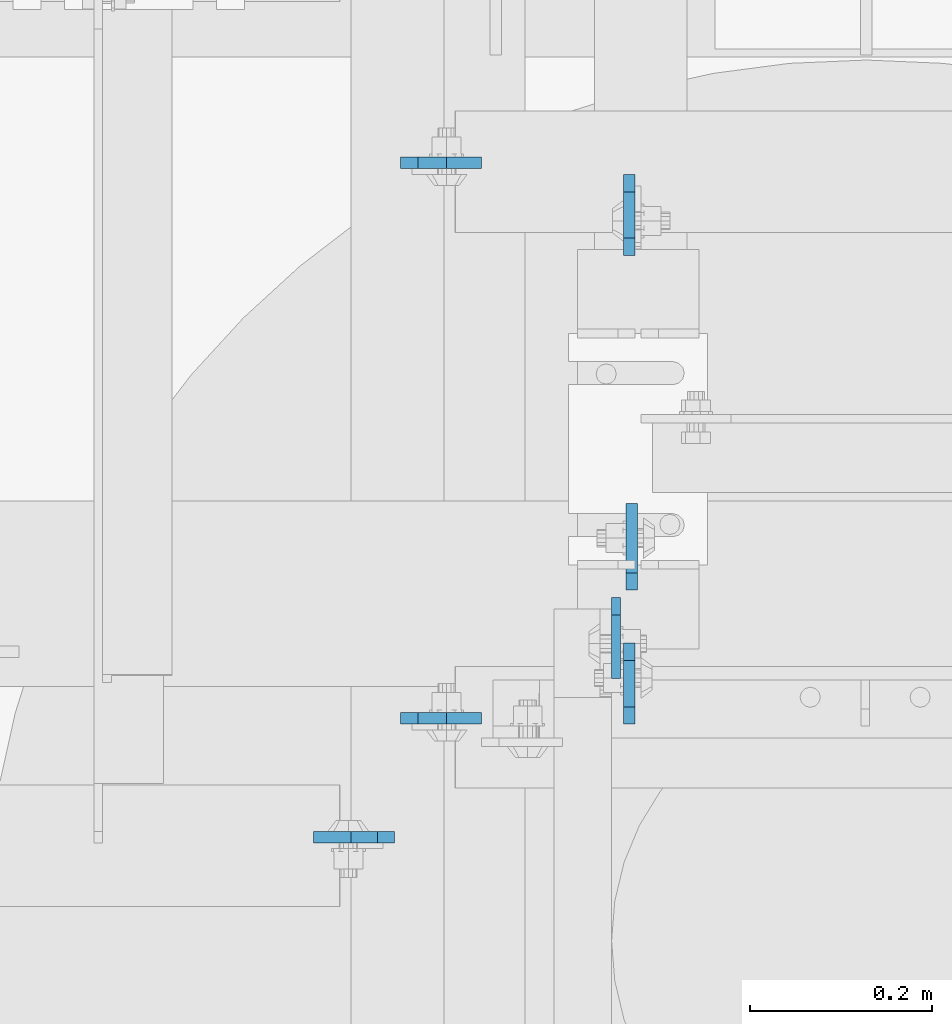
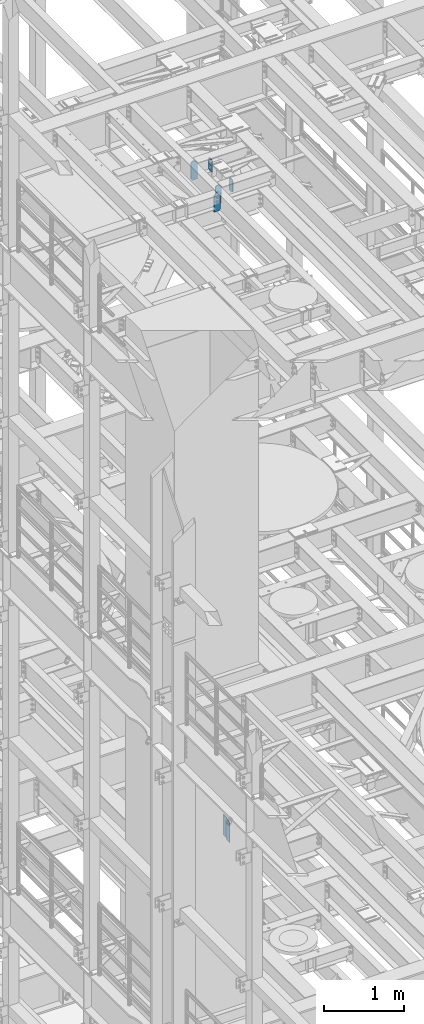
# One storey, part 1633 of 1876: 7 plates, 4 elements without a shape of their own.
"""IFC2X3 building model written with IfcOpenShell, lengths in millimetres."""

from ifc_helpers import new_model, si_unit, frame, origin_with_axes, place, context, subcontext, project, spatial, faceted_brep, material, type_object, element, aggregate, save


model = new_model("IFC2X3")

# Units and contexts
model_context = context("Model", 3, precision=1e-05, world=origin_with_axes())
body_context = subcontext(model_context, "Body", "Model", "MODEL_VIEW")
ifc_project = project(units=[si_unit("LENGTHUNIT", "METRE", prefix="MILLI"), si_unit("AREAUNIT", "SQUARE_METRE"), si_unit("VOLUMEUNIT", "CUBIC_METRE"), si_unit("MASSUNIT", "GRAM", prefix="KILO"), si_unit("TIMEUNIT", "SECOND"), si_unit("PLANEANGLEUNIT", "RADIAN"), si_unit("SOLIDANGLEUNIT", "STERADIAN"), si_unit("THERMODYNAMICTEMPERATUREUNIT", "DEGREE_CELSIUS"), si_unit("LUMINOUSINTENSITYUNIT", "LUMEN")], contexts=[model_context])

# Site, building, storey
site_placement = place(None, origin_with_axes())
site = spatial("IfcSite", under=ifc_project, at=site_placement, CompositionType="ELEMENT")
building_placement = place(site_placement, origin_with_axes())
building = spatial("IfcBuilding", under=site, at=building_placement, Name="Undefined", CompositionType="ELEMENT")
storey_placement = place(building_placement, origin_with_axes())
storey = spatial("IfcBuildingStorey", under=building, at=storey_placement, Name="Undefined", CompositionType="ELEMENT", Elevation=0.0)

# Assembly, plate
assembly_1_placement = place(storey_placement, origin_with_axes())
assembly_1 = element("IfcElementAssembly", 1, at=assembly_1_placement, inside=storey, Name="BEAM", AssemblyPlace="NOTDEFINED", PredefinedType="RIGID_FRAME")
ifc_material = material(Name="STEEL/A36")
plate_type_1 = type_object("IfcPlateType", PredefinedType="NOTDEFINED")
plate_1_placement = place(assembly_1_placement, frame((3097.21299991607, 5552.28125, 7821.6125), z_axis=(0.0, 0.0, 1.0), x_axis=(0.0, -1.0, 0.0)))
plate_1 = element("IfcPlate", 2, at=plate_1_placement, type_object=plate_type_1, material=ifc_material, Name="PLATE", context=body_context, shape_type="Brep", body=[
    faceted_brep([(0.0, -4.76249999999982, 19.0499992370605), (-1.81898940354586e-12, -4.76250000000073, 296.862499237061), (0.0, 4.76249999999982, 296.862499237061), (0.0, 4.76249999999982, 19.0499992370605), (19.0499992370605, -4.76249999999982, 315.912506103516), (19.0499992370605, 4.76249999999982, 315.912506103516), (88.9000015258789, -4.76249999999982, 315.912506103516), (88.9000015258789, 4.76249999999982, 315.912506103516), (88.9000015258789, -4.76249999999982, 0.0), (88.9000015258789, 4.76249999999982, 0.0), (19.0499992370605, -4.76249999999982, 0.0), (19.0499992370605, 4.76249999999982, 0.0)], [[[0, 1, 2, 3]], [[1, 4, 5, 2]], [[4, 6, 7, 5]], [[6, 8, 9, 7]], [[8, 10, 11, 9]], [[10, 0, 3, 11]], [[5, 7, 9, 11, 3, 2]], [[10, 8, 6, 4, 1, 0]]]),
])

assembly_2_placement = place(storey_placement, origin_with_axes())
assembly_2 = element("IfcElementAssembly", 3, at=assembly_2_placement, inside=storey, Name="BEAM", AssemblyPlace="NOTDEFINED", PredefinedType="RIGID_FRAME")
plate_type_2 = type_object("IfcPlateType", PredefinedType="NOTDEFINED")
plate_2_placement = place(assembly_2_placement, frame((3111.88048414082, 6016.39856567383, 17786.35), z_axis=(0.0, 0.0, 1.0), x_axis=(0.0, -1.0, 0.0)))
plate_2 = element("IfcPlate", 4, at=plate_2_placement, type_object=plate_type_2, material=ifc_material, Name="PLATE", context=body_context, shape_type="Brep", body=[
    faceted_brep([(0.0, -6.35000000000196, 19.0499992370605), (0.0, -6.34999999999991, 169.862506866455), (0.0, 6.34999999999991, 169.862506866455), (0.0, 6.35000000000105, 19.0499992370605), (19.0499992370605, -6.34999999999991, 188.912506103516), (19.0499992370605, 6.34999999999991, 188.912506103516), (69.8500022888184, -6.34999999999991, 188.912506103516), (69.8500022888184, 6.34999999999991, 188.912506103516), (88.9000015258789, -6.34999999999991, 169.862506866455), (88.9000015258789, 6.34999999999991, 169.862506866455), (88.9000015258789, -6.34999999999991, 0.0), (88.9000015258789, 6.34999999999991, 0.0), (19.0499992370642, -6.35000000000105, 0.0), (19.0499992370633, 6.35000000000105, 0.0)], [[[0, 1, 2, 3]], [[1, 4, 5, 2]], [[4, 6, 7, 5]], [[6, 8, 9, 7]], [[8, 10, 11, 9]], [[10, 12, 13, 11]], [[12, 0, 3, 13]], [[5, 7, 9, 11, 13, 3, 2]], [[12, 10, 8, 6, 4, 1, 0]]]),
])
aggregate(assembly_2, [plate_2])

assembly_3_placement = place(storey_placement, origin_with_axes())
assembly_3 = element("IfcElementAssembly", 5, at=assembly_3_placement, inside=storey, Name="BEAM", AssemblyPlace="NOTDEFINED", PredefinedType="RIGID_FRAME")
plate_3_placement = place(assembly_3_placement, frame((3111.88048414082, 5413.14856567383, 17786.35), z_axis=(0.0, 0.0, 1.0), x_axis=(0.0, 1.0, 0.0)))
plate_3 = element("IfcPlate", 6, at=plate_3_placement, type_object=plate_type_2, material=ifc_material, Name="PLATE", context=body_context, shape_type="Brep", body=[
    faceted_brep([(0.0, -6.35000000000196, 19.0499992370605), (0.0, -6.34999999999991, 169.862506866455), (0.0, 6.34999999999991, 169.862506866455), (0.0, 6.35000000000105, 19.0499992370605), (19.0499992370605, -6.34999999999991, 188.912506103516), (19.0499992370605, 6.34999999999991, 188.912506103516), (69.8500022888184, -6.34999999999991, 188.912506103516), (69.8500022888184, 6.34999999999991, 188.912506103516), (88.9000015258789, -6.34999999999991, 169.862506866455), (88.9000015258789, 6.34999999999991, 169.862506866455), (88.9000015258789, -6.34999999999991, 0.0), (88.9000015258789, 6.34999999999991, 0.0), (19.0499992370642, -6.35000000000105, 0.0), (19.0499992370633, 6.35000000000105, 0.0)], [[[0, 1, 2, 3]], [[1, 4, 5, 2]], [[4, 6, 7, 5]], [[6, 8, 9, 7]], [[8, 10, 11, 9]], [[10, 12, 13, 11]], [[12, 0, 3, 13]], [[5, 7, 9, 11, 13, 3, 2]], [[12, 10, 8, 6, 4, 1, 0]]]),
])
aggregate(assembly_3, [plate_3])

# Assembly, plates
assembly_4_placement = place(storey_placement, origin_with_axes())
assembly_4 = element("IfcElementAssembly", 7, at=assembly_4_placement, inside=storey, Name="BEAM", AssemblyPlace="NOTDEFINED", PredefinedType="RIGID_FRAME")
plate_4_placement = place(assembly_4_placement, frame((2860.675, 6029.09856576919, 17686.3375), z_axis=(0.0, 0.0, 1.0), x_axis=(1.0, 0.0, 0.0)))
plate_4 = element("IfcPlate", 8, at=plate_4_placement, type_object=plate_type_2, material=ifc_material, Name="PLATE", context=body_context, shape_type="Brep", body=[
    faceted_brep([(0.0, -6.35000000000196, 19.0499992370605), (0.0, -6.35000000000036, 271.462512969971), (0.0, 6.35000000000036, 271.462512969971), (0.0, 6.35000000000105, 19.0499992370605), (19.0499992370605, -6.35000000000036, 290.512512207031), (19.0499992370605, 6.35000000000036, 290.512512207031), (50.8000030517578, -6.35000000000036, 290.512512207031), (50.8000030517578, 6.35000000000036, 290.512512207031), (88.9000015258789, -6.35000000000036, 252.41251373291), (88.9000015258789, 6.35000000000036, 252.41251373291), (88.9000015258789, -6.34999999999991, 0.0), (88.9000015258789, 6.34999999999991, 0.0), (19.0499992370642, -6.35000000000105, 0.0), (19.0499992370633, 6.35000000000105, 0.0)], [[[0, 1, 2, 3]], [[1, 4, 5, 2]], [[4, 6, 7, 5]], [[6, 8, 9, 7]], [[8, 10, 11, 9]], [[10, 12, 13, 11]], [[12, 0, 3, 13]], [[5, 7, 9, 11, 13, 3, 2]], [[12, 10, 8, 6, 4, 1, 0]]]),
])
plate_5_placement = place(assembly_4_placement, frame((2860.675, 5419.49856576919, 17686.3375), z_axis=(0.0, 0.0, 1.0), x_axis=(1.0, 0.0, 0.0)))
plate_5 = element("IfcPlate", 9, at=plate_5_placement, type_object=plate_type_2, material=ifc_material, Name="PLATE", context=body_context, shape_type="Brep", body=[
    faceted_brep([(0.0, -6.35000000000196, 19.0499992370605), (0.0, -6.35000000000036, 271.462512969971), (0.0, 6.35000000000036, 271.462512969971), (0.0, 6.35000000000105, 19.0499992370605), (19.0499992370605, -6.35000000000036, 290.512512207031), (19.0499992370605, 6.35000000000036, 290.512512207031), (50.8000030517578, -6.35000000000036, 290.512512207031), (50.8000030517578, 6.35000000000036, 290.512512207031), (88.9000015258789, -6.35000000000036, 252.41251373291), (88.9000015258789, 6.35000000000036, 252.41251373291), (88.9000015258789, -6.34999999999991, 0.0), (88.9000015258789, 6.34999999999991, 0.0), (19.0499992370642, -6.35000000000105, 0.0), (19.0499992370633, 6.35000000000105, 0.0)], [[[0, 1, 2, 3]], [[1, 4, 5, 2]], [[4, 6, 7, 5]], [[6, 8, 9, 7]], [[8, 10, 11, 9]], [[10, 12, 13, 11]], [[12, 0, 3, 13]], [[5, 7, 9, 11, 13, 3, 2]], [[12, 10, 8, 6, 4, 1, 0]]]),
])
plate_6_placement = place(assembly_4_placement, frame((2854.325, 5289.32356576919, 17686.3375), z_axis=(0.0, 0.0, 1.0), x_axis=(-1.0, 0.0, 0.0)))
plate_6 = element("IfcPlate", 10, at=plate_6_placement, type_object=plate_type_2, material=ifc_material, Name="PLATE", context=body_context, shape_type="Brep", body=[
    faceted_brep([(0.0, -6.35000000000036, 271.462512969971), (19.0499992370605, -6.35000000000036, 290.512512207031), (19.0499992370605, 6.35000000000036, 290.512512207031), (0.0, 6.35000000000036, 271.462512969971), (0.0, -6.35000000000196, 19.0499992370605), (0.0, 6.35000000000105, 19.0499992370605), (19.0499992370642, -6.35000000000105, 0.0), (19.0499992370633, 6.35000000000105, 0.0), (88.9000015258789, -6.34999999999991, 0.0), (88.9000015258789, 6.34999999999991, 0.0), (88.9000015258789, -6.35000000000036, 249.237510681152), (47.625, -6.35000000000036, 290.512512207031), (47.625, 6.35000000000036, 290.512512207031), (88.9000015258789, 6.35000000000036, 249.237510681152)], [[[0, 1, 2, 3]], [[4, 0, 3, 5]], [[6, 4, 5, 7]], [[8, 6, 7, 9]], [[6, 8, 10, 11, 1, 0, 4]], [[1, 11, 12, 2]], [[2, 12, 13, 9, 7, 5, 3]], [[10, 8, 9, 13]], [[11, 10, 13, 12]]]),
])
aggregate(assembly_4, [plate_4, plate_5, plate_6])

# Plate
plate_type_3 = type_object("IfcPlateType", PredefinedType="NOTDEFINED")
plate_7_placement = place(assembly_1_placement, frame((3114.67499990463, 5560.21875, 7821.6125), z_axis=(0.0, 0.0, 1.0), x_axis=(0.0, 1.0, 0.0)))
plate_7 = element("IfcPlate", 11, at=plate_7_placement, type_object=plate_type_3, material=ifc_material, Name="PLATE", context=body_context, shape_type="Brep", body=[
    faceted_brep([(0.0, -6.35000000000196, 19.0499992370605), (-9.09494701772928e-13, -6.34999999999764, 296.862506866455), (1.81898940354586e-12, 6.34999999999786, 296.862506866455), (0.0, 6.35000000000105, 19.0499992370605), (19.0499992370587, -6.34999999999604, 315.912506103516), (19.0499992370624, 6.34999999999945, 315.912506103516), (95.25, -6.35000000000036, 315.912506103516), (95.25, 6.35000000000036, 315.912506103516), (95.25, -6.35000000000036, 0.0), (95.25, 6.35000000000036, 0.0), (19.0499992370642, -6.35000000000105, 0.0), (19.0499992370633, 6.35000000000105, 0.0)], [[[0, 1, 2, 3]], [[1, 4, 5, 2]], [[4, 6, 7, 5]], [[6, 8, 9, 7]], [[8, 10, 11, 9]], [[10, 0, 3, 11]], [[5, 7, 9, 11, 3, 2]], [[10, 8, 6, 4, 1, 0]]]),
])

aggregate(assembly_1, [plate_1, plate_7])

save(model, "model.ifc")
